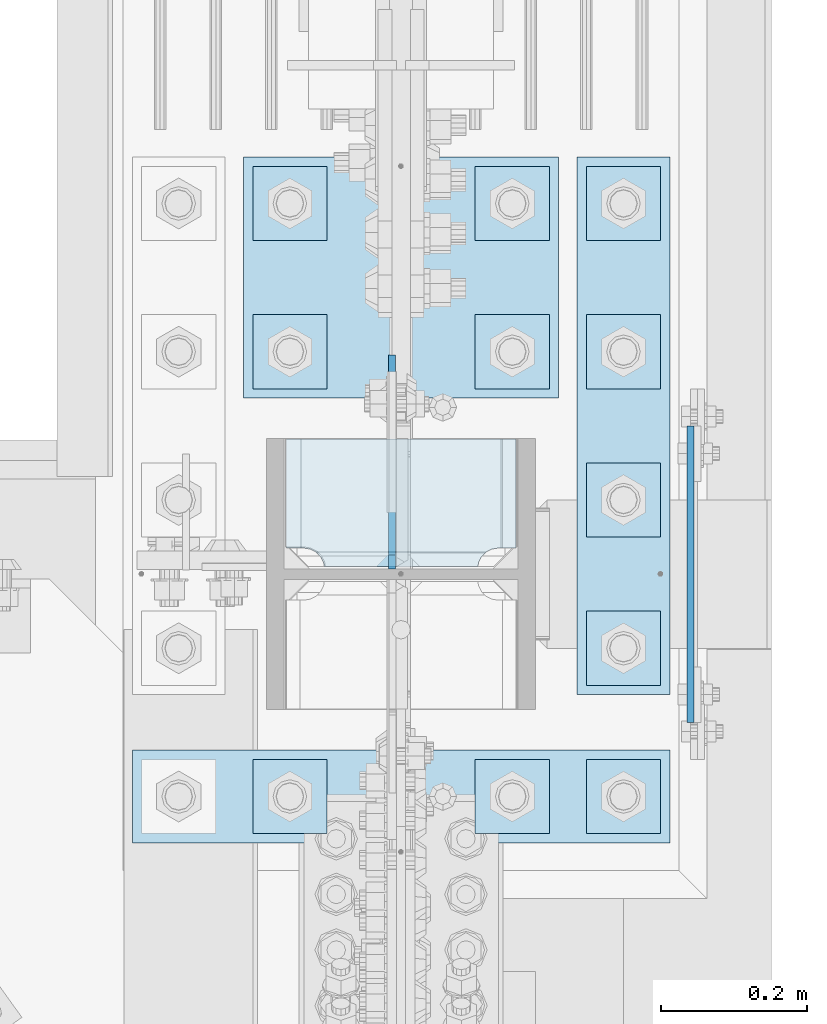
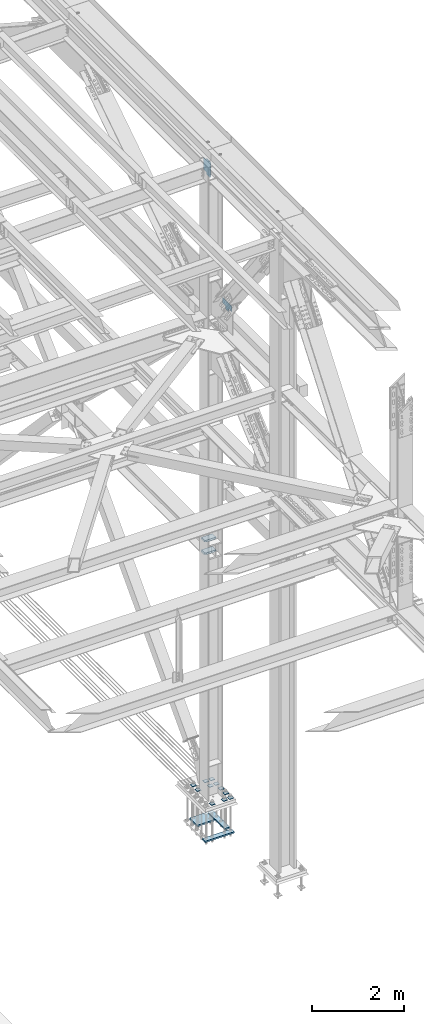
# One storey, part 3634 of 3843: 18 plates, 2 elements without a shape of their own.
"""IFC2X3 building model written with IfcOpenShell, lengths in millimetres."""

from ifc_helpers import new_model, si_unit, frame, origin_with_axes, place, context, subcontext, project, spatial, faceted_brep, material, type_object, element, aggregate, save


model = new_model("IFC2X3")

# Units and contexts
model_context = context("Model", 3, precision=1e-05, world=origin_with_axes())
body_context = subcontext(model_context, "Body", "Model", "MODEL_VIEW")
ifc_project = project(units=[si_unit("LENGTHUNIT", "METRE", prefix="MILLI"), si_unit("AREAUNIT", "SQUARE_METRE"), si_unit("VOLUMEUNIT", "CUBIC_METRE"), si_unit("MASSUNIT", "GRAM", prefix="KILO"), si_unit("TIMEUNIT", "SECOND"), si_unit("PLANEANGLEUNIT", "RADIAN"), si_unit("SOLIDANGLEUNIT", "STERADIAN"), si_unit("THERMODYNAMICTEMPERATUREUNIT", "DEGREE_CELSIUS"), si_unit("LUMINOUSINTENSITYUNIT", "LUMEN")], contexts=[model_context])

# Site, building, storey
site_placement = place(None, origin_with_axes())
site = spatial("IfcSite", under=ifc_project, at=site_placement, CompositionType="ELEMENT")
building_placement = place(site_placement, origin_with_axes())
building = spatial("IfcBuilding", under=site, at=building_placement, Name="Undefined", CompositionType="ELEMENT")
storey_placement = place(building_placement, origin_with_axes())
storey = spatial("IfcBuildingStorey", under=building, at=storey_placement, Name="Undefined", CompositionType="ELEMENT", Elevation=0.0)

# Assembly, plates
assembly_1_placement = place(storey_placement, origin_with_axes())
assembly_1 = element("IfcElementAssembly", 1, at=assembly_1_placement, inside=storey, Name="COLUMN", AssemblyPlace="NOTDEFINED", PredefinedType="RIGID_FRAME")
ifc_material = material(Name="STEEL/A572-50")
plate_type_1 = type_object("IfcPlateType", PredefinedType="NOTDEFINED")
plate_1_placement = place(assembly_1_placement, frame((86045.675, 92278.2, 42367.2), z_axis=(0.0, 0.0, 1.0), x_axis=(0.0, -1.0, 0.0)))
plate_1 = element("IfcPlate", 2, at=plate_1_placement, type_object=plate_type_1, material=ifc_material, Name="PLATE", context=body_context, shape_type="Brep", body=[
    faceted_brep([(0.0, -4.76249999999709, 0.0), (-3.49245965480804e-10, -4.76249999999709, 76.1999999999462), (-3.49245965480804e-10, 4.76249999999709, 76.1999999999462), (0.0, 4.76249999999709, 0.0), (-139.699996948242, -4.76249999999709, 76.1999969482422), (-139.699996948242, 4.76249999999709, 76.1999969482422), (-139.699996948242, -4.76249999999709, 228.600006103516), (-139.699996948242, 4.76249999999709, 228.600006103516), (266.700012207031, -4.76249999999709, 228.600006103516), (266.700012207031, 4.76249999999709, 228.600006103516), (266.700012207031, -4.76249999999709, 76.1999969482422), (266.700012207031, 4.76249999999709, 76.1999969482422), (126.999992370605, -4.76249999999709, 76.1999969482422), (126.999992370605, 4.76249999999709, 76.1999969482422), (126.999992370605, -4.76249999999709, 0.0), (126.999992370605, 4.76249999999709, 0.0)], [[[0, 1, 2, 3]], [[1, 4, 5, 2]], [[4, 6, 7, 5]], [[6, 8, 9, 7]], [[8, 10, 11, 9]], [[10, 12, 13, 11]], [[12, 14, 15, 13]], [[14, 0, 3, 15]], [[5, 7, 9, 11, 13, 15, 3, 2]], [[14, 12, 10, 8, 6, 4, 1, 0]]]),
])
plate_type_2 = type_object("IfcPlateType", PredefinedType="NOTDEFINED")
plate_2_placement = place(assembly_1_placement, frame((85809.1375, 92399.64375, 36085.4625), z_axis=(-1.0, 0.0, 0.0), x_axis=(0.0, -1.0, 0.0)))
plate_2 = element("IfcPlate", 3, at=plate_2_placement, type_object=plate_type_2, material=ifc_material, Name="PLATE", context=body_context, shape_type="Brep", body=[
    faceted_brep([(161.004039019055, 6.12926429974323, 50.105160468549), (154.682341820269, 17.0787650381244, 43.7834632697632), (154.460792336729, 17.4625000000015, 43.3486479258863), (154.460792336729, 17.4625000000015, 277.326339867082), (154.682341820269, 17.0787650381244, 276.891524523206), (161.004039019055, 6.1292642997505, 270.56982732442), (168.969842201739, -7.66791153574013, 266.511047877182), (174.624750047686, -17.4625000000015, 265.615410186598), (174.624750047686, -17.4625000000015, 55.0595898134052), (168.969842201739, -7.66791153574013, 54.1639399157866), (0.0, 17.4625000000015, 297.335542336732), (0.0, -17.4625000000015, 317.499500047692), (149.225002288818, -17.4625000000015, 317.499500047663), (149.225002288818, 17.4625000000015, 297.335542336703), (149.225002288818, 17.4625000000015, 23.338457663267), (149.225002288818, -17.4625000000015, 3.17449995230709), (0.0, -17.4625000000015, 3.17449995232164), (0.0, 17.4625000000015, 23.3384576632816), (149.225002288818, -17.4625000000015, 293.687488555908), (149.225002288818, 17.4625000000015, 293.687488555908), (150.623562373032, -17.4625000000015, 284.857327705889), (150.623562373032, 17.4625000000015, 284.857327705889), (154.682341820269, -17.4625000000015, 276.891524523206), (161.004039019055, -17.4625000000015, 270.56982732442), (168.969842201739, -17.4625000000015, 266.511047877182), (168.969842201739, -17.4625000000015, 54.1639399157866), (161.004039019055, -17.4625000000015, 50.105160468549), (154.682341820269, -17.4625000000015, 43.7834632697632), (150.623562373032, -17.4625000000015, 35.8176600870793), (150.623562373032, 17.4625000000015, 35.8176600870793), (149.225002288818, -17.4625000000015, 26.9874992370605), (149.225002288818, 17.4625000000015, 26.9874992370605)], [[[0, 1, 2, 3, 4, 5, 6, 7, 8, 9]], [[10, 11, 12, 13]], [[14, 15, 16, 17]], [[11, 10, 17, 16]], [[18, 19, 13, 12]], [[18, 20, 21, 19]], [[21, 20, 22, 4, 3]], [[22, 23, 5, 4]], [[23, 24, 6, 5]], [[24, 7, 6]], [[25, 9, 8]], [[25, 26, 0, 9]], [[26, 27, 1, 0]], [[27, 28, 29, 2, 1]], [[28, 30, 31, 29]], [[31, 30, 15, 14]], [[29, 31, 14, 17, 10, 13, 19, 21, 3, 2]], [[15, 30, 28, 27, 26, 25, 8, 7, 24, 23, 22, 20, 18, 12, 11, 16]]]),
])
plate_3_placement = place(assembly_1_placement, frame((85809.1375, 92399.64375, 36418.8375), z_axis=(-1.0, 0.0, 0.0), x_axis=(0.0, -1.0, 0.0)))
plate_3 = element("IfcPlate", 4, at=plate_3_placement, type_object=plate_type_2, material=ifc_material, Name="PLATE", context=body_context, shape_type="Brep", body=[
    faceted_brep([(161.004039019055, 6.12926429974323, 50.105160468549), (154.682341820269, 17.0787650381244, 43.7834632697632), (154.460792336729, 17.4625000000015, 43.3486479258863), (154.460792336729, 17.4625000000015, 277.326339867082), (154.682341820269, 17.0787650381244, 276.891524523206), (161.004039019055, 6.1292642997505, 270.56982732442), (168.969842201739, -7.66791153574013, 266.511047877182), (174.624750047686, -17.4625000000015, 265.615410186598), (174.624750047686, -17.4625000000015, 55.0595898134052), (168.969842201739, -7.66791153574013, 54.1639399157866), (0.0, 17.4625000000015, 297.335542336732), (0.0, -17.4625000000015, 317.499500047692), (149.225002288818, -17.4625000000015, 317.499500047663), (149.225002288818, 17.4625000000015, 297.335542336703), (149.225002288818, 17.4625000000015, 23.338457663267), (149.225002288818, -17.4625000000015, 3.17449995230709), (0.0, -17.4625000000015, 3.17449995232164), (0.0, 17.4625000000015, 23.3384576632816), (149.225002288818, -17.4625000000015, 293.687488555908), (149.225002288818, 17.4625000000015, 293.687488555908), (150.623562373032, -17.4625000000015, 284.857327705889), (150.623562373032, 17.4625000000015, 284.857327705889), (154.682341820269, -17.4625000000015, 276.891524523206), (161.004039019055, -17.4625000000015, 270.56982732442), (168.969842201739, -17.4625000000015, 266.511047877182), (168.969842201739, -17.4625000000015, 54.1639399157866), (161.004039019055, -17.4625000000015, 50.105160468549), (154.682341820269, -17.4625000000015, 43.7834632697632), (150.623562373032, -17.4625000000015, 35.8176600870793), (150.623562373032, 17.4625000000015, 35.8176600870793), (149.225002288818, -17.4625000000015, 26.9874992370605), (149.225002288818, 17.4625000000015, 26.9874992370605)], [[[0, 1, 2, 3, 4, 5, 6, 7, 8, 9]], [[10, 11, 12, 13]], [[14, 15, 16, 17]], [[11, 10, 17, 16]], [[18, 19, 13, 12]], [[18, 20, 21, 19]], [[21, 20, 22, 4, 3]], [[22, 23, 5, 4]], [[23, 24, 6, 5]], [[24, 7, 6]], [[25, 9, 8]], [[25, 26, 0, 9]], [[26, 27, 1, 0]], [[27, 28, 29, 2, 1]], [[28, 30, 31, 29]], [[31, 30, 15, 14]], [[29, 31, 14, 17, 10, 13, 19, 21, 3, 2]], [[15, 30, 28, 27, 26, 25, 8, 7, 24, 23, 22, 20, 18, 12, 11, 16]]]),
])

assembly_2_placement = place(storey_placement, origin_with_axes())
assembly_2 = element("IfcElementAssembly", 5, at=assembly_2_placement, inside=storey, Name="TEMPLATE", AssemblyPlace="NOTDEFINED", PredefinedType="RIGID_FRAME")
plate_type_3 = type_object("IfcPlateType", PredefinedType="NOTDEFINED")
plate_4_placement = place(assembly_2_placement, frame((85902.8, 91960.7, 29686.25), z_axis=(0.0, -1.0, 0.0), x_axis=(1.0, 0.0, 0.0)))
plate_4 = element("IfcPlate", 6, at=plate_4_placement, type_object=plate_type_3, material=ifc_material, Name="Washer Plate", context=body_context, shape_type="Brep", body=[
    faceted_brep([(0.0, -6.3499999046162, 0.0), (-1.67347025126219e-10, -6.35000000000582, 101.600000000151), (-1.67347025126219e-10, 6.35000000000582, 101.600000000151), (7.27595761418343e-12, 6.3499999046162, 0.0), (101.599998474121, -6.34999999999854, 101.599998474121), (101.599998474121, 6.34999999999854, 101.599998474121), (101.6, -6.34999999999854, 0.0), (101.6, 6.34999999999854, 0.0)], [[[0, 1, 2, 3]], [[1, 4, 5, 2]], [[4, 6, 7, 5]], [[6, 0, 3, 7]], [[5, 7, 3, 2]], [[6, 4, 1, 0]]]),
])
plate_5_placement = place(assembly_2_placement, frame((85902.8, 92163.9, 29686.25), z_axis=(0.0, -1.0, 0.0), x_axis=(1.0, 0.0, 0.0)))
plate_5 = element("IfcPlate", 7, at=plate_5_placement, type_object=plate_type_3, material=ifc_material, Name="Washer Plate", context=body_context, shape_type="Brep", body=[
    faceted_brep([(0.0, -6.3499999046162, 0.0), (-1.67347025126219e-10, -6.35000000000582, 101.600000000151), (-1.67347025126219e-10, 6.35000000000582, 101.600000000151), (7.27595761418343e-12, 6.3499999046162, 0.0), (101.599998474121, -6.34999999999854, 101.599998474121), (101.599998474121, 6.34999999999854, 101.599998474121), (101.6, -6.34999999999854, 0.0), (101.6, 6.34999999999854, 0.0)], [[[0, 1, 2, 3]], [[1, 4, 5, 2]], [[4, 6, 7, 5]], [[6, 0, 3, 7]], [[5, 7, 3, 2]], [[6, 4, 1, 0]]]),
])
plate_6_placement = place(assembly_2_placement, frame((85902.8, 92367.1, 29686.25), z_axis=(0.0, -1.0, 0.0), x_axis=(1.0, 0.0, 0.0)))
plate_6 = element("IfcPlate", 8, at=plate_6_placement, type_object=plate_type_3, material=ifc_material, Name="Washer Plate", context=body_context, shape_type="Brep", body=[
    faceted_brep([(0.0, -6.3499999046162, 0.0), (-1.67347025126219e-10, -6.35000000000582, 101.600000000151), (-1.67347025126219e-10, 6.35000000000582, 101.600000000151), (7.27595761418343e-12, 6.3499999046162, 0.0), (101.599998474121, -6.34999999999854, 101.599998474121), (101.599998474121, 6.34999999999854, 101.599998474121), (101.6, -6.34999999999854, 0.0), (101.6, 6.34999999999854, 0.0)], [[[0, 1, 2, 3]], [[1, 4, 5, 2]], [[4, 6, 7, 5]], [[6, 0, 3, 7]], [[5, 7, 3, 2]], [[6, 4, 1, 0]]]),
])
plate_7_placement = place(assembly_2_placement, frame((85902.8, 92570.3, 29686.25), z_axis=(0.0, -1.0, 0.0), x_axis=(1.0, 0.0, 0.0)))
plate_7 = element("IfcPlate", 9, at=plate_7_placement, type_object=plate_type_3, material=ifc_material, Name="Washer Plate", context=body_context, shape_type="Brep", body=[
    faceted_brep([(0.0, -6.3499999046162, 0.0), (-1.67347025126219e-10, -6.35000000000582, 101.600000000151), (-1.67347025126219e-10, 6.35000000000582, 101.600000000151), (7.27595761418343e-12, 6.3499999046162, 0.0), (101.599998474121, -6.34999999999854, 101.599998474121), (101.599998474121, 6.34999999999854, 101.599998474121), (101.6, -6.34999999999854, 0.0), (101.6, 6.34999999999854, 0.0)], [[[0, 1, 2, 3]], [[1, 4, 5, 2]], [[4, 6, 7, 5]], [[6, 0, 3, 7]], [[5, 7, 3, 2]], [[6, 4, 1, 0]]]),
])
plate_8_placement = place(assembly_2_placement, frame((85902.8, 92773.5, 29686.25), z_axis=(0.0, -1.0, 0.0), x_axis=(1.0, 0.0, 0.0)))
plate_8 = element("IfcPlate", 10, at=plate_8_placement, type_object=plate_type_3, material=ifc_material, Name="Washer Plate", context=body_context, shape_type="Brep", body=[
    faceted_brep([(0.0, -6.3499999046162, 0.0), (-1.67347025126219e-10, -6.35000000000582, 101.600000000151), (-1.67347025126219e-10, 6.35000000000582, 101.600000000151), (7.27595761418343e-12, 6.3499999046162, 0.0), (101.599998474121, -6.34999999999854, 101.599998474121), (101.599998474121, 6.34999999999854, 101.599998474121), (101.6, -6.34999999999854, 0.0), (101.6, 6.34999999999854, 0.0)], [[[0, 1, 2, 3]], [[1, 4, 5, 2]], [[4, 6, 7, 5]], [[6, 0, 3, 7]], [[5, 7, 3, 2]], [[6, 4, 1, 0]]]),
])
plate_9_placement = place(assembly_2_placement, frame((85750.4, 91960.7, 29686.25), z_axis=(0.0, -1.0, 0.0), x_axis=(1.0, 0.0, 0.0)))
plate_9 = element("IfcPlate", 11, at=plate_9_placement, type_object=plate_type_3, material=ifc_material, Name="Washer Plate", context=body_context, shape_type="Brep", body=[
    faceted_brep([(0.0, -6.3499999046162, 0.0), (-1.67347025126219e-10, -6.35000000000582, 101.600000000151), (-1.67347025126219e-10, 6.35000000000582, 101.600000000151), (7.27595761418343e-12, 6.3499999046162, 0.0), (101.599998474121, -6.34999999999854, 101.599998474121), (101.599998474121, 6.34999999999854, 101.599998474121), (101.6, -6.34999999999854, 0.0), (101.6, 6.34999999999854, 0.0)], [[[0, 1, 2, 3]], [[1, 4, 5, 2]], [[4, 6, 7, 5]], [[6, 0, 3, 7]], [[5, 7, 3, 2]], [[6, 4, 1, 0]]]),
])
plate_10_placement = place(assembly_2_placement, frame((85750.4, 92570.3, 29686.25), z_axis=(0.0, -1.0, 0.0), x_axis=(1.0, 0.0, 0.0)))
plate_10 = element("IfcPlate", 12, at=plate_10_placement, type_object=plate_type_3, material=ifc_material, Name="Washer Plate", context=body_context, shape_type="Brep", body=[
    faceted_brep([(0.0, -6.3499999046162, 0.0), (-1.67347025126219e-10, -6.35000000000582, 101.600000000151), (-1.67347025126219e-10, 6.35000000000582, 101.600000000151), (7.27595761418343e-12, 6.3499999046162, 0.0), (101.599998474121, -6.34999999999854, 101.599998474121), (101.599998474121, 6.34999999999854, 101.599998474121), (101.6, -6.34999999999854, 0.0), (101.6, 6.34999999999854, 0.0)], [[[0, 1, 2, 3]], [[1, 4, 5, 2]], [[4, 6, 7, 5]], [[6, 0, 3, 7]], [[5, 7, 3, 2]], [[6, 4, 1, 0]]]),
])
plate_11_placement = place(assembly_2_placement, frame((85750.4, 92773.5, 29686.25), z_axis=(0.0, -1.0, 0.0), x_axis=(1.0, 0.0, 0.0)))
plate_11 = element("IfcPlate", 13, at=plate_11_placement, type_object=plate_type_3, material=ifc_material, Name="Washer Plate", context=body_context, shape_type="Brep", body=[
    faceted_brep([(0.0, -6.3499999046162, 0.0), (-1.67347025126219e-10, -6.35000000000582, 101.600000000151), (-1.67347025126219e-10, 6.35000000000582, 101.600000000151), (7.27595761418343e-12, 6.3499999046162, 0.0), (101.599998474121, -6.34999999999854, 101.599998474121), (101.599998474121, 6.34999999999854, 101.599998474121), (101.6, -6.34999999999854, 0.0), (101.6, 6.34999999999854, 0.0)], [[[0, 1, 2, 3]], [[1, 4, 5, 2]], [[4, 6, 7, 5]], [[6, 0, 3, 7]], [[5, 7, 3, 2]], [[6, 4, 1, 0]]]),
])
plate_12_placement = place(assembly_2_placement, frame((85445.6, 91960.7, 29686.25), z_axis=(0.0, -1.0, 0.0), x_axis=(1.0, 0.0, 0.0)))
plate_12 = element("IfcPlate", 14, at=plate_12_placement, type_object=plate_type_3, material=ifc_material, Name="Washer Plate", context=body_context, shape_type="Brep", body=[
    faceted_brep([(0.0, -6.3499999046162, 0.0), (-1.67347025126219e-10, -6.35000000000582, 101.600000000151), (-1.67347025126219e-10, 6.35000000000582, 101.600000000151), (7.27595761418343e-12, 6.3499999046162, 0.0), (101.599998474121, -6.34999999999854, 101.599998474121), (101.599998474121, 6.34999999999854, 101.599998474121), (101.6, -6.34999999999854, 0.0), (101.6, 6.34999999999854, 0.0)], [[[0, 1, 2, 3]], [[1, 4, 5, 2]], [[4, 6, 7, 5]], [[6, 0, 3, 7]], [[5, 7, 3, 2]], [[6, 4, 1, 0]]]),
])
plate_13_placement = place(assembly_2_placement, frame((85445.6, 92570.3, 29686.25), z_axis=(0.0, -1.0, 0.0), x_axis=(1.0, 0.0, 0.0)))
plate_13 = element("IfcPlate", 15, at=plate_13_placement, type_object=plate_type_3, material=ifc_material, Name="Washer Plate", context=body_context, shape_type="Brep", body=[
    faceted_brep([(0.0, -6.3499999046162, 0.0), (-1.67347025126219e-10, -6.35000000000582, 101.600000000151), (-1.67347025126219e-10, 6.35000000000582, 101.600000000151), (7.27595761418343e-12, 6.3499999046162, 0.0), (101.599998474121, -6.34999999999854, 101.599998474121), (101.599998474121, 6.34999999999854, 101.599998474121), (101.6, -6.34999999999854, 0.0), (101.6, 6.34999999999854, 0.0)], [[[0, 1, 2, 3]], [[1, 4, 5, 2]], [[4, 6, 7, 5]], [[6, 0, 3, 7]], [[5, 7, 3, 2]], [[6, 4, 1, 0]]]),
])
plate_14_placement = place(assembly_2_placement, frame((85445.6, 92773.5, 29686.25), z_axis=(0.0, -1.0, 0.0), x_axis=(1.0, 0.0, 0.0)))
plate_14 = element("IfcPlate", 16, at=plate_14_placement, type_object=plate_type_3, material=ifc_material, Name="Washer Plate", context=body_context, shape_type="Brep", body=[
    faceted_brep([(0.0, -6.3499999046162, 0.0), (-1.67347025126219e-10, -6.35000000000582, 101.600000000151), (-1.67347025126219e-10, 6.35000000000582, 101.600000000151), (7.27595761418343e-12, 6.3499999046162, 0.0), (101.599998474121, -6.34999999999854, 101.599998474121), (101.599998474121, 6.34999999999854, 101.599998474121), (101.6, -6.34999999999854, 0.0), (101.6, 6.34999999999854, 0.0)], [[[0, 1, 2, 3]], [[1, 4, 5, 2]], [[4, 6, 7, 5]], [[6, 0, 3, 7]], [[5, 7, 3, 2]], [[6, 4, 1, 0]]]),
])

# Plate
plate_type_4 = type_object("IfcPlateType", PredefinedType="NOTDEFINED")
plate_15_placement = place(assembly_1_placement, frame((85636.0995000839, 92221.84375, 46021.625), z_axis=(0.0, 0.707106781186548, 0.707106781186548), x_axis=(5.70000238222118e-08, 0.707106781186546, -0.707106781186546)))
plate_15 = element("IfcPlate", 17, at=plate_15_placement, type_object=plate_type_4, material=ifc_material, Name="PLATE", context=body_context, shape_type="Brep", body=[
    faceted_brep([(0.0, -4.76249999999709, 0.0), (-273.897811691269, -4.76249999999709, 273.897811691328), (-273.897811691269, 4.76249999999709, 273.897811691328), (0.0, 4.76249999999709, 0.0), (-273.897811691131, -4.76249999999709, 300.83858005454), (-273.897811691131, 4.76249999999709, 300.83858005454), (-161.644610177136, -4.76249999999709, 413.09178156851), (-161.644610177136, 4.76249999999709, 413.09178156851), (-132.458777648957, -4.76249999999709, 383.905949040323), (-132.458777648957, 4.76249999999709, 383.905949040323), (-128.338601180818, -4.76249999999709, 381.152935139853), (-128.338601180818, 4.76249999999709, 381.152935139853), (-123.478521662786, -4.76249999999709, 380.186205217266), (-123.478521662786, 4.76249999999709, 380.186205217266), (-118.618442144754, -4.76249999999709, 381.152935139853), (-118.618442144754, 4.76249999999709, 381.152935139853), (-114.498265676601, -4.76249999999709, 383.90594904032), (-114.498265676601, 4.76249999999709, 383.90594904032), (-42.0949505651442, -4.76249999999709, 456.309264151772), (-42.0949505651442, 4.76249999999709, 456.309264151772), (182.411452460481, -4.76249999999709, 231.802861126107), (182.411452460481, 4.76249999999709, 231.802861126107), (110.008137349017, -4.76249999999709, 159.399546014654), (110.008137349017, 4.76249999999709, 159.399546014654), (107.255123448544, -4.76249999999709, 155.279369546512), (107.255123448544, 4.76249999999709, 155.279369546512), (106.288393525967, -4.76249999999709, 150.41929002848), (106.288393525967, 4.76249999999709, 150.41929002848), (107.255123448551, -4.76249999999709, 145.559210510441), (107.255123448551, 4.76249999999709, 145.559210510441), (110.008137349017, -4.76249999999709, 141.439034042298), (110.008137349017, 4.76249999999709, 141.439034042298), (139.193969877184, -4.76249999999709, 112.253201514119), (139.193969877184, 4.76249999999709, 112.253201514119), (26.9407683631998, -4.76249999999709, 1.30967237055302e-10), (26.9407683631998, 4.76249999999709, 1.30967237055302e-10)], [[[0, 1, 2, 3]], [[1, 4, 5, 2]], [[4, 6, 7, 5]], [[6, 8, 9, 7]], [[8, 10, 11, 9]], [[10, 12, 13, 11]], [[12, 14, 15, 13]], [[14, 16, 17, 15]], [[16, 18, 19, 17]], [[18, 20, 21, 19]], [[20, 22, 23, 21]], [[22, 24, 25, 23]], [[24, 26, 27, 25]], [[26, 28, 29, 27]], [[28, 30, 31, 29]], [[30, 32, 33, 31]], [[32, 34, 35, 33]], [[34, 0, 3, 35]], [[5, 7, 9, 11, 13, 15, 17, 19, 21, 23, 25, 27, 29, 31, 33, 35, 3, 2]], [[34, 32, 30, 28, 26, 24, 22, 20, 18, 16, 14, 12, 10, 8, 6, 4, 1, 0]]]),
])

aggregate(assembly_1, [plate_15, plate_1, plate_2, plate_3])

plate_type_5 = type_object("IfcPlateType", PredefinedType="NOTDEFINED")
plate_16_placement = place(assembly_2_placement, frame((85280.5, 91973.4, 28784.55), z_axis=(0.0, -1.0, 0.0), x_axis=(1.0, 0.0, 0.0)))
plate_16 = element("IfcPlate", 18, at=plate_16_placement, type_object=plate_type_5, material=ifc_material, Name="PLATE", context=body_context, shape_type="Brep", body=[
    faceted_brep([(0.0, -19.0500000000029, 0.0), (0.0, -19.0499999999993, 127.0), (0.0, 19.0499999999993, 127.0), (0.0, 19.0500000000029, 0.0), (736.599975585938, -19.0499999999993, 127.0), (736.599975585938, 19.0499999999993, 127.0), (736.599975585938, -19.0499999999993, 0.0), (736.599975585938, 19.0499999999993, 0.0)], [[[0, 1, 2, 3]], [[1, 4, 5, 2]], [[4, 6, 7, 5]], [[6, 0, 3, 7]], [[5, 7, 3, 2]], [[6, 4, 1, 0]]]),
])

plate_17_placement = place(assembly_2_placement, frame((85890.1, 92786.2, 28784.55), z_axis=(0.0, -1.0, 0.0), x_axis=(1.0, 0.0, 0.0)))
plate_17 = element("IfcPlate", 19, at=plate_17_placement, type_object=plate_type_5, material=ifc_material, Name="PLATE", context=body_context, shape_type="Brep", body=[
    faceted_brep([(0.0, -19.0500000000029, 0.0), (0.0, -19.0499999999993, 736.600036621094), (0.0, 19.0499999999993, 736.600036621094), (0.0, 19.0500000000029, 0.0), (127.0, -19.0499999999993, 736.600036621094), (127.0, 19.0499999999993, 736.600036621094), (127.0, -19.0499999999993, 0.0), (127.0, 19.0499999999993, 0.0)], [[[0, 1, 2, 3]], [[1, 4, 5, 2]], [[4, 6, 7, 5]], [[6, 0, 3, 7]], [[5, 7, 3, 2]], [[6, 4, 1, 0]]]),
])

plate_type_6 = type_object("IfcPlateType", PredefinedType="NOTDEFINED")
plate_18_placement = place(assembly_2_placement, frame((85432.9, 92786.2, 28784.55), z_axis=(0.0, -1.0, 0.0), x_axis=(1.0, 0.0, 0.0)))
plate_18 = element("IfcPlate", 20, at=plate_18_placement, type_object=plate_type_6, material=ifc_material, Name="PLATE", context=body_context, shape_type="Brep", body=[
    faceted_brep([(0.0, -19.0500000000029, 0.0), (0.0, -19.0499999999993, 330.200012207031), (0.0, 19.0499999999993, 330.200012207031), (0.0, 19.0500000000029, 0.0), (431.799957275391, -19.0499999999993, 330.200012207031), (431.799957275391, 19.0499999999993, 330.200012207031), (431.799957275391, -19.0499999999993, 0.0), (431.799957275391, 19.0499999999993, 0.0)], [[[0, 1, 2, 3]], [[1, 4, 5, 2]], [[4, 6, 7, 5]], [[6, 0, 3, 7]], [[5, 7, 3, 2]], [[6, 4, 1, 0]]]),
])

aggregate(assembly_2, [plate_16, plate_17, plate_18, plate_4, plate_5, plate_6, plate_7, plate_8, plate_9, plate_10, plate_11, plate_12, plate_13, plate_14])

save(model, "model.ifc")
